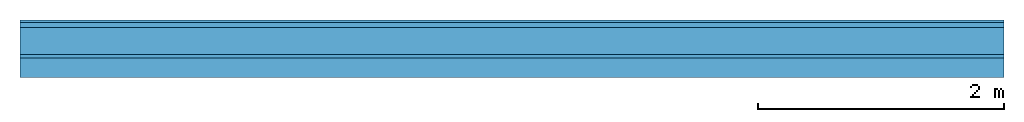
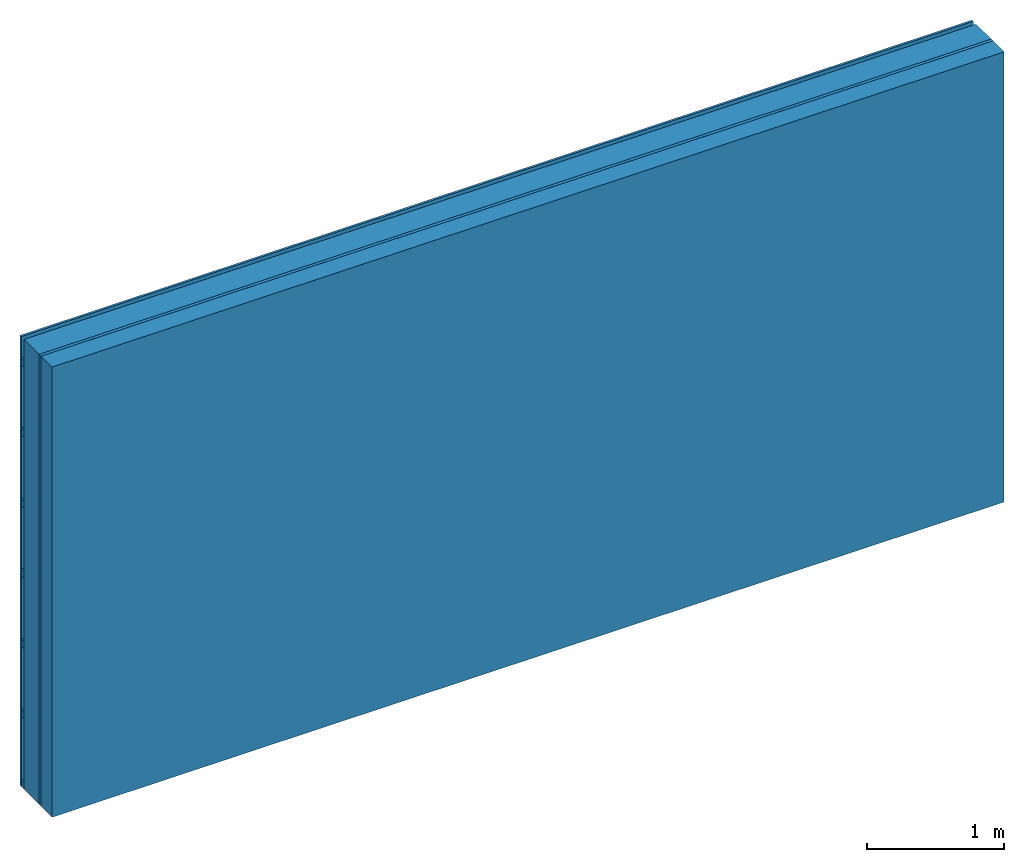
# One storey: 3 plates, 2 members, 1 element without a shape of its own.
"""IFC4 building model written with IfcOpenShell, lengths in metres."""

import ifcopenshell
import ifcopenshell.guid

model = None  # the IFC model being written
_history = None  # IfcOwnerHistory: only IFC2X3 demands one
_inside = {}  # id of a spatial element -> (the spatial element, [elements in it])
_under = {}  # id of a project, library or spatial element -> (it, [spatial elements below it])
_declared = {}  # id of a project -> (the project, [libraries it declares])
_typed = {}  # id of a type object -> (the type object, [elements of that type])
_made_of = {}  # id of a material, layer set ... -> (it, [elements and type objects made of it])


def new_model(schema):
    """Start an empty IFC model of exactly this schema.

    Asked for "IFC4X3", IfcOpenShell would pick the latest addendum, in which some entities
    have other attributes; the version numbers below select the first issue.
    IFC2X3 requires an IfcOwnerHistory on every rooted entity: one is made here for all.
    """
    global model, _history
    if schema == "IFC4X3":
        model = ifcopenshell.file(schema_version=(4, 3, 0, 0))
    else:
        model = ifcopenshell.file(schema=schema)
    _inside.clear()
    _under.clear()
    _declared.clear()
    _typed.clear()
    _made_of.clear()
    _history = None
    if model.schema == "IFC2X3":
        org = make("IfcOrganization", Name="unknown")
        user = make(
            "IfcPersonAndOrganization",
            ThePerson=make("IfcPerson", FamilyName="unknown"),
            TheOrganization=org,
        )
        app = make(
            "IfcApplication",
            ApplicationDeveloper=org,
            Version="unknown",
            ApplicationFullName="unknown",
            ApplicationIdentifier="unknown",
        )
        _history = make(
            "IfcOwnerHistory",
            OwningUser=user,
            OwningApplication=app,
            ChangeAction="ADDED",
            CreationDate=0,
        )
    return model


def make(cls, **values):
    """One entity of the class cls with the attributes given. An attribute that is None is left unset."""
    return model.create_entity(
        cls, **{name: value for name, value in values.items() if value is not None}
    )


def rooted(cls, **values):
    """An entity with a GlobalId (a new one), such as an element, a storey or a relation."""
    return make(cls, GlobalId=ifcopenshell.guid.new(), OwnerHistory=_history, **values)


def si_unit(unit_type, name, prefix=None):
    """IfcSIUnit, for example si_unit("LENGTHUNIT", "METRE", prefix="MILLI")."""
    return make("IfcSIUnit", UnitType=unit_type, Prefix=prefix, Name=name)


def derived_unit(unit_type, elements):
    """IfcDerivedUnit: a product of units, each with its exponent."""
    return make(
        "IfcDerivedUnit",
        Elements=[
            make("IfcDerivedUnitElement", Unit=unit, Exponent=power)
            for unit, power in elements
        ],
        UnitType=unit_type,
    )


def assignment(units):
    """IfcUnitAssignment: the units of a project."""
    return None if units is None else make("IfcUnitAssignment", Units=units)


def point(xyz):
    """IfcCartesianPoint."""
    return None if xyz is None else make("IfcCartesianPoint", Coordinates=xyz)


def direction(xyz):
    """IfcDirection."""
    return None if xyz is None else make("IfcDirection", DirectionRatios=xyz)


def frame(location, z_axis=None, x_axis=None):
    """IfcAxis2Placement3D, a coordinate frame: its origin and axes. An axis left out is left unset."""
    return make(
        "IfcAxis2Placement3D",
        Location=point(location),
        Axis=direction(z_axis),
        RefDirection=direction(x_axis),
    )


def frame_2d(location, x_axis=None):
    """IfcAxis2Placement2D, a coordinate frame in the plane: its origin and x axis."""
    return make(
        "IfcAxis2Placement2D", Location=point(location), RefDirection=direction(x_axis)
    )


def origin():
    """The frame at (0, 0, 0) with its axes left unset."""
    return frame((0.0, 0.0, 0.0))


def origin_with_axes():
    """The frame at (0, 0, 0) with the z axis (0, 0, 1) and the x axis (1, 0, 0) written out."""
    return frame((0.0, 0.0, 0.0), z_axis=(0.0, 0.0, 1.0), x_axis=(1.0, 0.0, 0.0))


def place(relative_to, where):
    """IfcLocalPlacement: puts the frame where relative to a parent placement (None: the world)."""
    return make(
        "IfcLocalPlacement", PlacementRelTo=relative_to, RelativePlacement=where
    )


def context(
    kind, dimensions, precision=None, world=None, true_north=None, identifier=None
):
    """IfcGeometricRepresentationContext, for example the 3D "Model" context."""
    return make(
        "IfcGeometricRepresentationContext",
        ContextIdentifier=identifier,
        ContextType=kind,
        CoordinateSpaceDimension=dimensions,
        Precision=precision,
        WorldCoordinateSystem=world,
        TrueNorth=true_north,
    )


def project(units=None, contexts=None):
    """IfcProject with its units and contexts."""
    return rooted(
        "IfcProject",
        Name="project",
        RepresentationContexts=contexts,
        UnitsInContext=assignment(units),
    )


def spatial(cls, under=None, at=None, **own):
    """A site, building, storey or space (cls), placed at a placement, below another one or the project."""
    s = rooted(cls, ObjectPlacement=at, **own)
    if under is not None:
        _under.setdefault(under.id(), (under, []))[1].append(s)
    return s


def profile(cls, at=None, kind="AREA", **sizes):
    """A parametric profile (cls). Its sizes go by their IFC names, for example OverallWidth=200.0."""
    return make(cls, ProfileType=kind, Position=at, **sizes)


def rectangle(**sizes):
    """IfcRectangleProfileDef."""
    return profile("IfcRectangleProfileDef", **sizes)


def extrude(swept, where, along, depth):
    """IfcExtrudedAreaSolid: the profile swept, set in the frame where, extruded along a direction by depth."""
    return make(
        "IfcExtrudedAreaSolid",
        SweptArea=swept,
        Position=where,
        ExtrudedDirection=direction(along),
        Depth=depth,
    )


def shape(context_of_items, identifier, shape_type, items):
    """IfcShapeRepresentation: the items that make up one representation, for example the "Body"."""
    return make(
        "IfcShapeRepresentation",
        ContextOfItems=context_of_items,
        RepresentationIdentifier=identifier,
        RepresentationType=shape_type,
        Items=items,
    )


def material(Name=None, Category=None):
    """IfcMaterial."""
    return make("IfcMaterial", Name=Name, Category=Category)


def layer(
    of_material, thickness, ventilated=None, Name=None, Category=None, Priority=None
):
    """IfcMaterialLayer: one layer of a wall or slab, of a material (None: an air gap)."""
    return make(
        "IfcMaterialLayer",
        Material=of_material,
        LayerThickness=thickness,
        IsVentilated=ventilated,
        Name=Name,
        Category=Category,
        Priority=Priority,
    )


def layer_set(layers, Name=None):
    """IfcMaterialLayerSet."""
    return make("IfcMaterialLayerSet", MaterialLayers=layers, LayerSetName=Name)


def made_of(thing, what):
    """Note that an element or type object is made of a material, layer set ...; save() writes the relation."""
    if what is not None:
        _made_of.setdefault(what.id(), (what, []))[1].append(thing)
    return thing


def type_object(cls, material=None, **own):
    """A type object (cls), such as IfcWallType, which elements share."""
    return made_of(rooted(cls, **own), material)


def element(
    cls,
    number,
    at=None,
    inside=None,
    cuts=None,
    type_object=None,
    material=None,
    context=None,
    identifier="Body",
    shape_type=None,
    held_by="IfcProductDefinitionShape",
    body=None,
    shapes=None,
    **own,
):
    """One element of the class cls, such as IfcWall. Its Tag is "e" and its number.

    at: its placement. inside: the storey or other place that contains it. cuts: it is an
    opening in that element (IfcRelVoidsElement). A single representation is given by context,
    identifier, shape_type and body (its items); several are given by shapes. held_by: the class
    of the entity that holds the representations. save() writes the other relations.
    """
    e = rooted(cls, Tag="e%d" % number, ObjectPlacement=at, **own)
    if body is not None:
        shapes = [shape(context, identifier, shape_type, body)]
    if shapes is not None:
        e.Representation = make(held_by, Representations=shapes)
    if inside is not None:
        _inside.setdefault(inside.id(), (inside, []))[1].append(e)
    if cuts is not None:
        rooted(
            "IfcRelVoidsElement", RelatingBuildingElement=cuts, RelatedOpeningElement=e
        )
    if type_object is not None:
        _typed.setdefault(type_object.id(), (type_object, []))[1].append(e)
    return made_of(e, material)


def aggregate(whole, parts):
    """IfcRelAggregates: a whole, such as a stair, and the parts it consists of."""
    return rooted("IfcRelAggregates", RelatingObject=whole, RelatedObjects=parts)


def save(model, path):
    """Write the relations noted so far, then the file.

    IfcRelAggregates (storeys below a building ...), IfcRelContainedInSpatialStructure (elements
    in a storey), IfcRelDefinesByType, IfcRelAssociatesMaterial and IfcRelDeclares: one each for
    every whole, place, type object, material and project.
    """
    for whole, parts in _under.values():
        aggregate(whole, parts)
    for where, things in _inside.values():
        rooted(
            "IfcRelContainedInSpatialStructure",
            RelatedElements=things,
            RelatingStructure=where,
        )
    for kind, things in _typed.values():
        rooted("IfcRelDefinesByType", RelatedObjects=things, RelatingType=kind)
    for what, things in _made_of.values():
        rooted("IfcRelAssociatesMaterial", RelatedObjects=things, RelatingMaterial=what)
    for by, libraries in _declared.values():
        rooted("IfcRelDeclares", RelatingContext=by, RelatedDefinitions=libraries)
    model.write(path)


model = new_model("IFC4")

# Units and contexts
plan_context = context("Plan", 3, precision=1e-05, world=origin(), true_north=direction((0.0, 1.0)))
model_context = context("Model", 3, precision=1e-05, world=origin(), true_north=direction((0.0, 1.0)))
ifc_project = project(units=[si_unit("LENGTHUNIT", "METRE"), derived_unit("SOUNDPRESSUREUNIT", [(si_unit("PRESSUREUNIT", "PASCAL", prefix="MICRO"), 0)]), si_unit("ENERGYUNIT", "JOULE", prefix="MEGA"), si_unit("MASSUNIT", "GRAM", prefix="KILO"), derived_unit("THERMALTRANSMITTANCEUNIT", [(si_unit("POWERUNIT", "WATT"), 1), (si_unit("AREAUNIT", "SQUARE_METRE"), -1), (si_unit("THERMODYNAMICTEMPERATUREUNIT", "KELVIN"), -1)]), derived_unit("AREADENSITYUNIT", [(si_unit("MASSUNIT", "GRAM", prefix="KILO"), 1), (si_unit("AREAUNIT", "SQUARE_METRE"), -1)]), derived_unit("USERDEFINED", [(si_unit("ENERGYUNIT", "JOULE", prefix="MEGA"), 1), (si_unit("AREAUNIT", "SQUARE_METRE"), -1)])], contexts=[plan_context, model_context])

# Site, building, storey
site = spatial("IfcSite", under=ifc_project)
building_placement = place(None, origin())
building = spatial("IfcBuilding", under=site, at=building_placement)
storey_placement = place(building_placement, origin())
storey = spatial("IfcBuildingStorey", under=building, at=storey_placement)

# Wall, members, plates
ifc_material_1 = material(Name="Wood cladding horizontal, closed")
ifc_layer_1 = layer(ifc_material_1, 0.02, Name="Cover 1st layer")
ifc_layer_2 = layer(None, 0.04, Name="Battens / profiles (ventilation)")
ifc_material_2 = material(Category="10.009")
ifc_layer_3 = layer(ifc_material_2, 0.22, Name="outside 2nd layer")
ifc_material_3 = material(Category="07.009")
ifc_layer_4 = layer(ifc_material_3, 0.027, Name="outside 1st layer")
ifc_material_4 = material(Name="Rigid, of the art")
ifc_layer_5 = layer(ifc_material_4, 0.0, Name="Bond")
ifc_layer_6 = layer(None, 0.16, Name="Support")
ifc_material_5 = material(Name="of the art")
ifc_layer_7 = layer(ifc_material_5, 0.0, Name="Bond")
ifc_layer_set = layer_set([ifc_layer_1, ifc_layer_2, ifc_layer_3, ifc_layer_4, ifc_layer_5, ifc_layer_6, ifc_layer_7])
wall_type = type_object("IfcWallType", Name="D1194", PredefinedType="NOTDEFINED", material=ifc_layer_set)
wall_placement = place(None, frame((0.0, 0.0, 0.0), z_axis=(0.0, -1.0, 0.0), x_axis=(1.0, 0.0, 0.0)))
wall = element("IfcWall", 1, at=wall_placement, inside=storey, type_object=wall_type, material=ifc_layer_set, Name="Wall #1")
ifc_material_6 = material()
member_1_placement = place(wall_placement, origin())
member_1 = element("IfcMember", 2, at=member_1_placement, material=ifc_material_6, Name="Battens / profiles (ventilation)", context=plan_context, shape_type="SweptSolid", body=[
    extrude(rectangle(XDim=0.06, YDim=0.04, at=frame_2d((0.03, 0.02), x_axis=(1.0, 0.0))), frame((0.0, 0.0, 0.02), z_axis=(1.0, 0.0, 0.0), x_axis=(0.0, 1.0, 0.0)), (0.0, 0.0, 1.0), 8.0),
    extrude(rectangle(XDim=0.06, YDim=0.04, at=frame_2d((0.03, 0.02), x_axis=(1.0, 0.0))), frame((0.0, 0.625, 0.02), z_axis=(1.0, 0.0, 0.0), x_axis=(0.0, 1.0, 0.0)), (0.0, 0.0, 1.0), 8.0),
    extrude(rectangle(XDim=0.06, YDim=0.04, at=frame_2d((0.03, 0.02), x_axis=(1.0, 0.0))), frame((0.0, 1.25, 0.02), z_axis=(1.0, 0.0, 0.0), x_axis=(0.0, 1.0, 0.0)), (0.0, 0.0, 1.0), 8.0),
    extrude(rectangle(XDim=0.06, YDim=0.04, at=frame_2d((0.03, 0.02), x_axis=(1.0, 0.0))), frame((0.0, 1.875, 0.02), z_axis=(1.0, 0.0, 0.0), x_axis=(0.0, 1.0, 0.0)), (0.0, 0.0, 1.0), 8.0),
    extrude(rectangle(XDim=0.06, YDim=0.04, at=frame_2d((0.03, 0.02), x_axis=(1.0, 0.0))), frame((0.0, 2.5, 0.02), z_axis=(1.0, 0.0, 0.0), x_axis=(0.0, 1.0, 0.0)), (0.0, 0.0, 1.0), 8.0),
    extrude(rectangle(XDim=0.06, YDim=0.04, at=frame_2d((0.03, 0.02), x_axis=(1.0, 0.0))), frame((0.0, 3.125, 0.02), z_axis=(1.0, 0.0, 0.0), x_axis=(0.0, 1.0, 0.0)), (0.0, 0.0, 1.0), 8.0),
    extrude(rectangle(XDim=0.06, YDim=0.04, at=frame_2d((0.03, 0.02), x_axis=(1.0, 0.0))), frame((0.0, 3.75, 0.02), z_axis=(1.0, 0.0, 0.0), x_axis=(0.0, 1.0, 0.0)), (0.0, 0.0, 1.0), 8.0),
])
ifc_material_7 = material(Name="Solid timber panel")
member_2_placement = place(wall_placement, origin())
member_2 = element("IfcMember", 3, at=member_2_placement, material=ifc_material_7, Name="Support", context=plan_context, shape_type="SweptSolid", body=[
    extrude(rectangle(XDim=1.0, YDim=0.16, at=frame_2d((0.5, 0.08), x_axis=(1.0, 0.0))), frame((0.0, 4.0, 0.307), z_axis=(0.0, -1.0, 0.0), x_axis=(1.0, 0.0, 0.0)), (0.0, 0.0, 1.0), 4.0),
    extrude(rectangle(XDim=1.0, YDim=0.16, at=frame_2d((0.5, 0.08), x_axis=(1.0, 0.0))), frame((1.0, 4.0, 0.307), z_axis=(0.0, -1.0, 0.0), x_axis=(1.0, 0.0, 0.0)), (0.0, 0.0, 1.0), 4.0),
    extrude(rectangle(XDim=1.0, YDim=0.16, at=frame_2d((0.5, 0.08), x_axis=(1.0, 0.0))), frame((2.0, 4.0, 0.307), z_axis=(0.0, -1.0, 0.0), x_axis=(1.0, 0.0, 0.0)), (0.0, 0.0, 1.0), 4.0),
    extrude(rectangle(XDim=1.0, YDim=0.16, at=frame_2d((0.5, 0.08), x_axis=(1.0, 0.0))), frame((3.0, 4.0, 0.307), z_axis=(0.0, -1.0, 0.0), x_axis=(1.0, 0.0, 0.0)), (0.0, 0.0, 1.0), 4.0),
    extrude(rectangle(XDim=1.0, YDim=0.16, at=frame_2d((0.5, 0.08), x_axis=(1.0, 0.0))), frame((4.0, 4.0, 0.307), z_axis=(0.0, -1.0, 0.0), x_axis=(1.0, 0.0, 0.0)), (0.0, 0.0, 1.0), 4.0),
    extrude(rectangle(XDim=1.0, YDim=0.16, at=frame_2d((0.5, 0.08), x_axis=(1.0, 0.0))), frame((5.0, 4.0, 0.307), z_axis=(0.0, -1.0, 0.0), x_axis=(1.0, 0.0, 0.0)), (0.0, 0.0, 1.0), 4.0),
    extrude(rectangle(XDim=1.0, YDim=0.16, at=frame_2d((0.5, 0.08), x_axis=(1.0, 0.0))), frame((6.0, 4.0, 0.307), z_axis=(0.0, -1.0, 0.0), x_axis=(1.0, 0.0, 0.0)), (0.0, 0.0, 1.0), 4.0),
    extrude(rectangle(XDim=1.0, YDim=0.16, at=frame_2d((0.5, 0.08), x_axis=(1.0, 0.0))), frame((7.0, 4.0, 0.307), z_axis=(0.0, -1.0, 0.0), x_axis=(1.0, 0.0, 0.0)), (0.0, 0.0, 1.0), 4.0),
])
plate_1_placement = place(wall_placement, origin())
plate_1 = element("IfcPlate", 4, at=plate_1_placement, material=ifc_material_1, Name="Cover 1st layer", context=plan_context, shape_type="SweptSolid", body=[
    extrude(rectangle(XDim=8.0, YDim=4.0, at=frame_2d((4.0, 2.0), x_axis=(1.0, 0.0))), origin_with_axes(), (0.0, 0.0, 1.0), 0.02),
])
plate_2_placement = place(wall_placement, origin())
plate_2 = element("IfcPlate", 5, at=plate_2_placement, material=ifc_material_2, Name="outside 2nd layer", context=plan_context, shape_type="SweptSolid", body=[
    extrude(rectangle(XDim=8.0, YDim=4.0, at=frame_2d((4.0, 2.0), x_axis=(1.0, 0.0))), frame((0.0, 0.0, 0.06), z_axis=(0.0, 0.0, 1.0), x_axis=(1.0, 0.0, 0.0)), (0.0, 0.0, 1.0), 0.22),
])
plate_3_placement = place(wall_placement, origin())
plate_3 = element("IfcPlate", 6, at=plate_3_placement, material=ifc_material_3, Name="outside 1st layer", context=plan_context, shape_type="SweptSolid", body=[
    extrude(rectangle(XDim=8.0, YDim=4.0, at=frame_2d((4.0, 2.0), x_axis=(1.0, 0.0))), frame((0.0, 0.0, 0.28), z_axis=(0.0, 0.0, 1.0), x_axis=(1.0, 0.0, 0.0)), (0.0, 0.0, 1.0), 0.027),
])
aggregate(wall, [plate_1, member_1, plate_2, plate_3, member_2])

save(model, "model.ifc")
